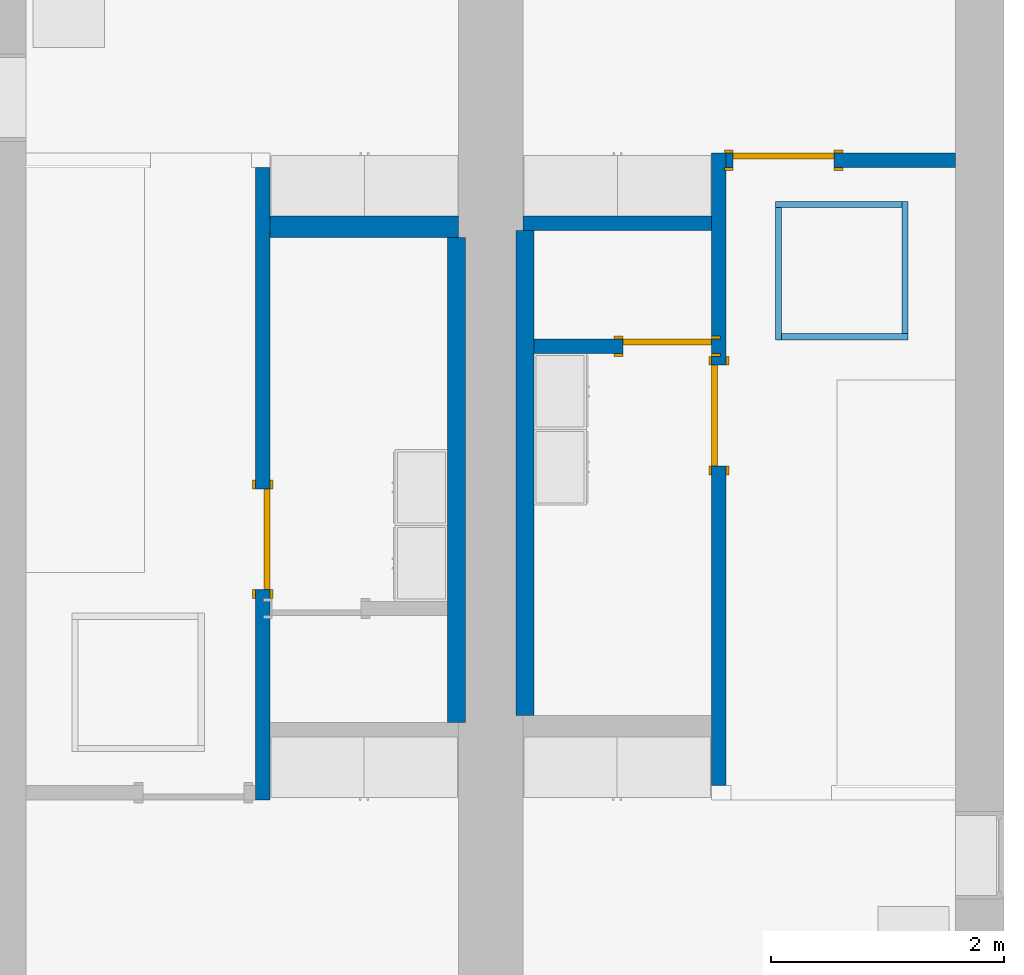
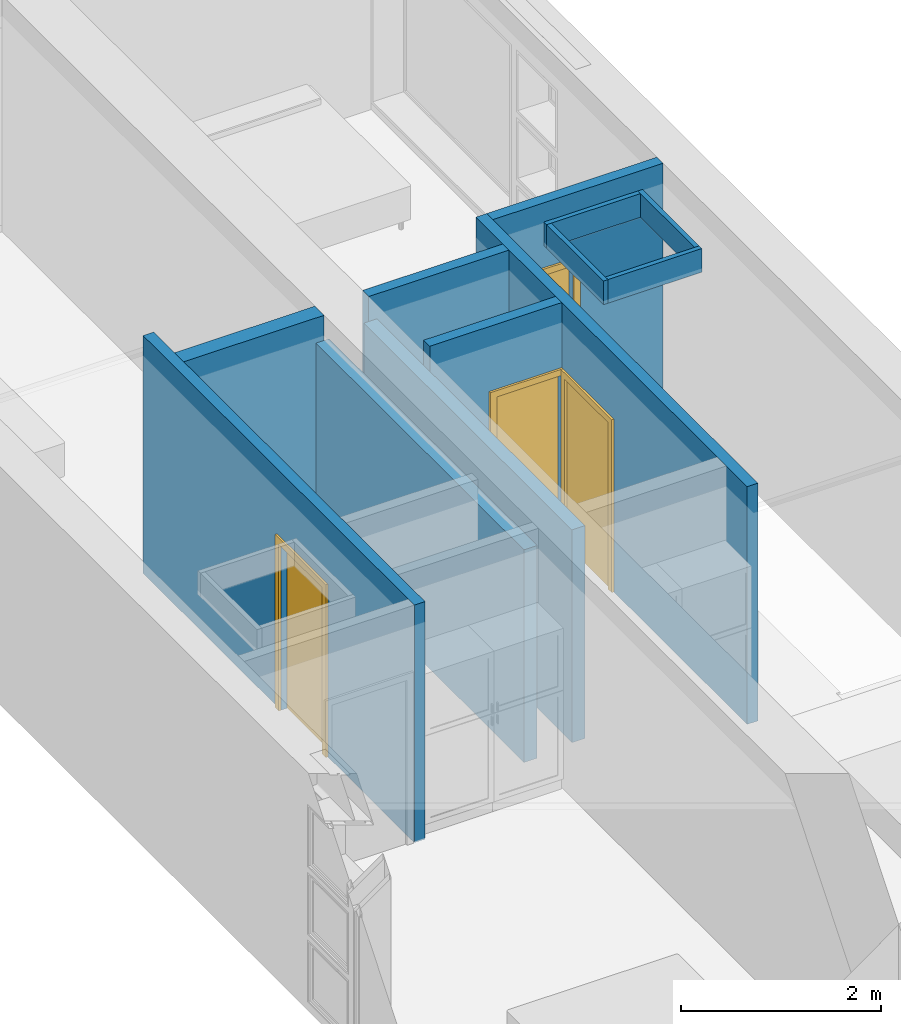
# One storey, part 3 of 16: 12 walls, 4 doors, 4 openings.
"""IFC2X3 building model written with IfcOpenShell, lengths in metres."""

from ifc_helpers import new_model, entity, si_unit, converted_unit, frame, frame_2d, origin, origin_2d_with_axis, place, context, project, spatial, polyline, rectangle, outline, extrude, source, transform, mapped, material, layer, layer_set, layer_usage, type_object, type_shapes, element, fill, save


model = new_model("IFC2X3")

# Units and contexts
model_context = context("Model", 3, precision=1e-09, world=origin())
plan_context = context("Plan", 3, precision=1e-09, world=origin())
ifc_project = project(units=[si_unit("LENGTHUNIT", "METRE"), si_unit("AREAUNIT", "SQUARE_METRE"), si_unit("VOLUMEUNIT", "CUBIC_METRE"), converted_unit("PLANEANGLEUNIT", "DEGREE", entity("IfcRatioMeasure", 0.01745329251994328), si_unit("PLANEANGLEUNIT", "RADIAN"), dimensions=[0, 0, 0, 0, 0, 0, 0]), si_unit("TIMEUNIT", "SECOND")], contexts=[model_context, plan_context])

# Site, building, storey
site_placement = place(None, origin())
site = spatial("IfcSite", under=ifc_project, at=site_placement, CompositionType="ELEMENT")
building_placement = place(site_placement, origin())
building = spatial("IfcBuilding", under=site, at=building_placement, CompositionType="ELEMENT")
storey_placement = place(building_placement, frame((0.0, 0.0, 3.100000000000378)))
storey = spatial("IfcBuildingStorey", under=building, at=storey_placement, Name="Level 2", CompositionType="ELEMENT", Elevation=3.100000000000378)

# Wall, opening, door
ifc_material_1 = material(Name="Plasterboard")
ifc_layer_1 = layer(ifc_material_1, 0.016)
ifc_material_2 = material(Name="Metal - Stud Layer")
ifc_layer_2 = layer(ifc_material_2, 0.092)
ifc_layer_3 = layer(ifc_material_1, 0.016)
ifc_layer_set_1 = layer_set([ifc_layer_1, ifc_layer_2, ifc_layer_3], Name="Basic Wall:Interior - Partition (92mm Stud)")
ifc_layer_usage_1 = layer_usage(ifc_layer_set_1, "AXIS2", "NEGATIVE", 0.062)
wall_1_placement = place(storey_placement, frame((2.444, -6.250000000000009, 0.0), z_axis=(0.0, 0.0, 1.0), x_axis=(0.0, -1.0, 0.0)))
wall_1 = element("IfcWallStandardCase", 1, at=wall_1_placement, inside=storey, material=ifc_layer_usage_1, Name="Basic Wall:Interior - Partition (92mm Stud)", ObjectType="Basic Wall:Interior - Partition (92mm Stud)", context=model_context, shape_type="SweptSolid", body=[
    extrude(rectangle(XDim=5.423999999999995, YDim=0.1240000000000002, at=frame_2d((2.711999999999998, 0.0), x_axis=(-1.0, 0.0))), origin(), (0.0, 0.0, 1.0), 2.900000000000012),
])
opening_1_placement = place(wall_1_placement, frame((2.75605117851058, -0.06200000000000567, 0.0)))
opening_1 = element("IfcOpeningElement", 2, at=opening_1_placement, cuts=wall_1, Name="M_Single-Flush:0864 x 2032mm:0864 x 2032mm:1", ObjectType="Opening", context=model_context, shape_type="SweptSolid", body=[
    extrude(rectangle(XDim=0.8639999999999994, YDim=2.032, at=frame_2d((1.016, 0.4319999999999993), x_axis=(0.0, 1.0))), frame((0.0, 0.0, 0.0), z_axis=(0.0, 1.0, 0.0), x_axis=(0.0, 0.0, 1.0)), (0.0, 0.0, 1.0), 0.124),
])
door_style_1 = type_object("IfcDoorStyle", Name="0864 x 2032mm", ConstructionType="NOTDEFINED", OperationType="SINGLE_SWING_RIGHT", ParameterTakesPrecedence=False, Sizeable=False)
shared_shape_1 = source(origin(), model_context, "Body", "SweptSolid", [
    extrude(outline(polyline([(-0.5079999999999999, -1.072999999999999), (0.5079999999999998, -1.072999999999999), (0.5079999999999998, 1.035000000000001), (0.4319999999999997, 1.035000000000001), (0.4319999999999997, -0.9970000000000019), (-0.4319999999999996, -0.9970000000000019), (-0.4319999999999996, 1.035000000000001), (-0.5079999999999999, 1.035000000000001), (-0.5079999999999999, -1.072999999999999)])), frame((0.4320000000000008, 0.1239999999999992, 1.035000000000001), z_axis=(0.0, 1.0, 0.0), x_axis=(1.0, 0.0, 0.0)), (0.0, 0.0, 1.0), 0.02499999999999444),
    extrude(outline(polyline([(-1.073, -0.5079999999999971), (1.035, -0.5079999999999971), (1.035, -0.4320000000000073), (-0.9969999999999997, -0.4320000000000073), (-0.9969999999999997, 0.4320000000000018), (1.035, 0.4320000000000018), (1.035, 0.5080000000000027), (-1.073, 0.5080000000000027), (-1.073, -0.5079999999999971)])), frame((0.4320000000000031, -0.02500000000000638, 1.035), z_axis=(0.0, 1.0, 0.0), x_axis=(0.0, 0.0, -1.0)), (0.0, 0.0, 1.0), 0.02500000000000558),
    extrude(rectangle(XDim=0.051, YDim=0.8639999999999998, at=origin_2d_with_axis()), frame((0.4320000000000005, 0.0984999999999992, 0.0), z_axis=(0.0, 0.0, 1.0), x_axis=(0.0, 1.0, 0.0)), (0.0, 0.0, 1.0), 2.032),
])
type_shapes(door_style_1, [shared_shape_1])
door_1_placement = place(opening_1_placement, origin())
door_1 = element("IfcDoor", 3, at=door_1_placement, inside=storey, type_object=door_style_1, Name="M_Single-Flush:0864 x 2032mm:0864 x 2032mm", ObjectType="0864 x 2032mm", OverallHeight=2.032, OverallWidth=0.8639999999999985, context=model_context, shape_type="MappedRepresentation", body=[
    mapped(shared_shape_1, transform((0.0, 0.0, 0.0), scale=1.0)),
])
fill(opening_1, door_1)

# Wall
ifc_layer_4 = layer(ifc_material_1, 0.016)
ifc_layer_5 = layer(ifc_material_2, 0.152)
ifc_layer_6 = layer(ifc_material_1, 0.016)
ifc_layer_set_2 = layer_set([ifc_layer_4, ifc_layer_5, ifc_layer_6], Name="Basic Wall:Interior - Plumbing (152mm Stud)")
ifc_layer_usage_2 = layer_usage(ifc_layer_set_2, "AXIS2", "NEGATIVE", 0.092)
wall_2_placement = place(storey_placement, frame((2.505999999999999, -6.758000000000003, 0.0)))
element("IfcWallStandardCase", 4, at=wall_2_placement, inside=storey, material=ifc_layer_usage_2, Name="Basic Wall:Interior - Plumbing (152mm Stud)", ObjectType="Basic Wall:Interior - Plumbing (152mm Stud)", context=model_context, shape_type="SweptSolid", body=[
    extrude(rectangle(XDim=1.618999999999992, YDim=0.1839999999999993, at=frame_2d((0.8094999999999958, 0.0), x_axis=(-1.0, 0.0))), origin(), (0.0, 0.0, 1.0), 2.900000000000012),
])

# Wall, opening, door
ifc_layer_usage_3 = layer_usage(ifc_layer_set_1, "AXIS2", "NEGATIVE", 0.062)
wall_3_placement = place(storey_placement, frame((6.356, -11.55, 0.0), z_axis=(0.0, 0.0, 1.0), x_axis=(0.0, 1.0, 0.0)))
wall_3 = element("IfcWallStandardCase", 5, at=wall_3_placement, inside=storey, material=ifc_layer_usage_3, Name="Basic Wall:Interior - Partition (92mm Stud)", ObjectType="Basic Wall:Interior - Partition (92mm Stud)", context=model_context, shape_type="SweptSolid", body=[
    extrude(rectangle(XDim=5.423999999999995, YDim=0.124, at=frame_2d((2.711999999999998, 0.0), x_axis=(-1.0, 0.0))), origin(), (0.0, 0.0, 1.0), 2.900000000000012),
])
opening_2_placement = place(wall_3_placement, frame((2.74061576492847, -0.0620000000000056, 0.0)))
opening_2 = element("IfcOpeningElement", 6, at=opening_2_placement, cuts=wall_3, Name="M_Single-Flush:0864 x 2032mm:0864 x 2032mm:1", ObjectType="Opening", context=model_context, shape_type="SweptSolid", body=[
    extrude(rectangle(XDim=0.8639999999999994, YDim=2.032, at=frame_2d((1.016, 0.4319999999999998), x_axis=(0.0, 1.0))), frame((0.0, 0.0, 0.0), z_axis=(0.0, 1.0, 0.0), x_axis=(0.0, 0.0, 1.0)), (0.0, 0.0, 1.0), 0.124),
])
door_2_placement = place(opening_2_placement, origin())
door_2 = element("IfcDoor", 7, at=door_2_placement, inside=storey, type_object=door_style_1, Name="M_Single-Flush:0864 x 2032mm:0864 x 2032mm", ObjectType="0864 x 2032mm", OverallHeight=2.032, OverallWidth=0.8639999999999995, context=model_context, shape_type="MappedRepresentation", body=[
    mapped(shared_shape_1, transform((0.0, 0.0, 0.0), scale=1.0)),
])
fill(opening_2, door_2)

ifc_layer_usage_4 = layer_usage(ifc_layer_set_1, "AXIS2", "NEGATIVE", 0.062)
wall_4_placement = place(storey_placement, frame((6.418000000000008, -6.188000000000002, 0.0)))
wall_4 = element("IfcWallStandardCase", 8, at=wall_4_placement, inside=storey, material=ifc_layer_usage_4, Name="Basic Wall:Interior - Partition (92mm Stud)", ObjectType="Basic Wall:Interior - Partition (92mm Stud)", context=model_context, shape_type="SweptSolid", body=[
    extrude(rectangle(XDim=1.964999999999982, YDim=0.124, at=frame_2d((0.982499999999991, 0.0), x_axis=(-1.0, 0.0))), origin(), (0.0, 0.0, 1.0), 2.900000000000012),
])
opening_3_placement = place(wall_4_placement, frame((0.06000000000000016, -0.0620000000000021, 0.0)))
opening_3 = element("IfcOpeningElement", 9, at=opening_3_placement, cuts=wall_4, Name="M_Single-Flush:0864 x 2032mm:0864 x 2032mm:1", ObjectType="Opening", context=model_context, shape_type="SweptSolid", body=[
    extrude(rectangle(XDim=0.8639999999999995, YDim=2.032, at=frame_2d((1.016, 0.432), x_axis=(0.0, -1.0))), frame((0.0, 0.0, 0.0), z_axis=(0.0, 1.0, 0.0), x_axis=(0.0, 0.0, 1.0)), (0.0, 0.0, 1.0), 0.124),
])
door_style_2 = type_object("IfcDoorStyle", Name="0864 x 2032mm", ConstructionType="NOTDEFINED", OperationType="SINGLE_SWING_LEFT", ParameterTakesPrecedence=False, Sizeable=False)
shared_shape_2 = source(origin(), model_context, "Body", "SweptSolid", [
    extrude(outline(polyline([(-0.5079999999999999, -1.072999999999999), (0.5079999999999998, -1.072999999999999), (0.5079999999999998, 1.035000000000001), (0.4319999999999997, 1.035000000000001), (0.4319999999999997, -0.9970000000000019), (-0.4319999999999996, -0.9970000000000019), (-0.4319999999999996, 1.035000000000001), (-0.5079999999999999, 1.035000000000001), (-0.5079999999999999, -1.072999999999999)])), frame((0.4320000000000002, 0.1489999999999882, 1.035000000000001), z_axis=(0.0, -1.0, 0.0), x_axis=(-1.0, 0.0, 0.0)), (0.0, 0.0, 1.0), 0.02499999999999444),
    extrude(outline(polyline([(-1.073, -0.5079999999999971), (1.035, -0.5079999999999971), (1.035, -0.4320000000000073), (-0.9969999999999997, -0.4320000000000073), (-0.9969999999999997, 0.4320000000000018), (1.035, 0.4320000000000018), (1.035, 0.5080000000000027), (-1.073, 0.5080000000000027), (-1.073, -0.5079999999999971)])), frame((0.4319999999999979, 0.0, 1.035), z_axis=(0.0, -1.0, 0.0), x_axis=(0.0, 0.0, -1.0)), (0.0, 0.0, 1.0), 0.02500000000000558),
    extrude(rectangle(XDim=0.8639999999999998, YDim=0.051, at=origin_2d_with_axis()), frame((0.4320000000000005, 0.09849999999999375, 0.0)), (0.0, 0.0, 1.0), 2.032),
])
type_shapes(door_style_2, [shared_shape_2])
door_3_placement = place(opening_3_placement, origin())
door_3 = element("IfcDoor", 10, at=door_3_placement, inside=storey, type_object=door_style_2, Name="M_Single-Flush:0864 x 2032mm:0864 x 2032mm", ObjectType="0864 x 2032mm", OverallHeight=2.032, OverallWidth=0.8639999999999995, context=model_context, shape_type="MappedRepresentation", body=[
    mapped(shared_shape_2, transform((0.0, 0.0, 0.0), scale=1.0)),
])
fill(opening_3, door_3)

# Walls
ifc_layer_usage_5 = layer_usage(ifc_layer_set_1, "AXIS2", "NEGATIVE", 0.062)
wall_5_placement = place(storey_placement, frame((4.674999999999989, -6.728000000000002, 0.0)))
element("IfcWallStandardCase", 11, at=wall_5_placement, inside=storey, material=ifc_layer_usage_5, Name="Basic Wall:Interior - Partition (92mm Stud)", ObjectType="Basic Wall:Interior - Partition (92mm Stud)", context=model_context, shape_type="SweptSolid", body=[
    extrude(rectangle(XDim=1.619000000000017, YDim=0.124, at=frame_2d((0.809500000000009, 0.0), x_axis=(-1.0, 0.0))), origin(), (0.0, 0.0, 1.0), 2.900000000000012),
])
ifc_layer_7 = layer(ifc_material_2, 0.136)
ifc_layer_8 = layer(ifc_material_1, 0.016)
ifc_layer_set_3 = layer_set([ifc_layer_7, ifc_layer_8], Name="Basic Wall:Interior - Furring (152 mm Stud)")
ifc_layer_usage_6 = layer_usage(ifc_layer_set_3, "AXIS2", "POSITIVE", -0.07600000000000001)
wall_6_placement = place(storey_placement, frame((4.693999999999989, -6.790000000000003, 0.0), z_axis=(0.0, 0.0, 1.0), x_axis=(0.0, -1.0, 0.0)))
element("IfcWallStandardCase", 12, at=wall_6_placement, inside=storey, material=ifc_layer_usage_6, Name="Basic Wall:Interior - Furring (152 mm Stud)", ObjectType="Basic Wall:Interior - Furring (152 mm Stud)", context=model_context, shape_type="SweptSolid", body=[
    extrude(rectangle(XDim=4.160000000000006, YDim=0.1520000000000001, at=frame_2d((2.080000000000003, 0.0), x_axis=(-1.0, 0.0))), origin(), (0.0, 0.0, 1.0), 2.595000000000012),
])
ifc_layer_usage_7 = layer_usage(ifc_layer_set_3, "AXIS2", "POSITIVE", -0.07600000000000001)
wall_7_placement = place(storey_placement, frame((4.105999999999982, -11.01, 0.0), z_axis=(0.0, 0.0, 1.0), x_axis=(0.0, 1.0, 0.0)))
element("IfcWallStandardCase", 13, at=wall_7_placement, inside=storey, material=ifc_layer_usage_7, Name="Basic Wall:Interior - Furring (152 mm Stud)", ObjectType="Basic Wall:Interior - Furring (152 mm Stud)", context=model_context, shape_type="SweptSolid", body=[
    extrude(rectangle(XDim=4.159999999999996, YDim=0.1520000000000001, at=frame_2d((2.079999999999998, 0.0), x_axis=(-1.0, 0.0))), origin(), (0.0, 0.0, 1.0), 2.595000000000012),
])

# Wall, opening, door
ifc_layer_usage_8 = layer_usage(ifc_layer_set_1, "AXIS2", "POSITIVE", -0.062)
wall_8_placement = place(storey_placement, frame((4.769999999999988, -7.783384235071523, 0.0)))
wall_8 = element("IfcWallStandardCase", 14, at=wall_8_placement, inside=storey, material=ifc_layer_usage_8, Name="Basic Wall:Interior - Partition (92mm Stud)", ObjectType="Basic Wall:Interior - Partition (92mm Stud)", context=model_context, shape_type="SweptSolid", body=[
    extrude(rectangle(XDim=1.524000000000019, YDim=0.124, at=frame_2d((0.7620000000000092, 0.0), x_axis=(-1.0, 0.0))), origin(), (0.0, 0.0, 1.0), 2.900000000000012),
])
opening_4_placement = place(wall_8_placement, frame((0.7613750000000165, -0.06200000000000323, 0.0)))
opening_4 = element("IfcOpeningElement", 15, at=opening_4_placement, cuts=wall_8, Name="M_Single-Flush:0762 x 2032mm:0762 x 2032mm:1", ObjectType="Opening", context=model_context, shape_type="SweptSolid", body=[
    extrude(rectangle(XDim=0.7619999999999997, YDim=2.032, at=frame_2d((1.016, 0.3809999999999995), x_axis=(0.0, 1.0))), frame((0.0, 0.0, 0.0), z_axis=(0.0, 1.0, 0.0), x_axis=(0.0, 0.0, 1.0)), (0.0, 0.0, 1.0), 0.124),
])
door_style_3 = type_object("IfcDoorStyle", Name="0762 x 2032mm", ConstructionType="NOTDEFINED", OperationType="SINGLE_SWING_RIGHT", ParameterTakesPrecedence=False, Sizeable=False)
shared_shape_3 = source(origin(), model_context, "Body", "SweptSolid", [
    extrude(outline(polyline([(-0.457, -1.072999999999999), (0.4569999999999999, -1.072999999999999), (0.4569999999999999, 1.035000000000001), (0.3809999999999998, 1.035000000000001), (0.3809999999999998, -0.9970000000000019), (-0.3809999999999997, -0.9970000000000019), (-0.3809999999999997, 1.035000000000001), (-0.457, 1.035000000000001), (-0.457, -1.072999999999999)])), frame((0.3810000000000009, 0.1239999999999993, 1.035000000000001), z_axis=(0.0, 1.0, 0.0), x_axis=(1.0, 0.0, 0.0)), (0.0, 0.0, 1.0), 0.02499999999999445),
    extrude(outline(polyline([(-1.073, -0.4569999999999971), (1.035, -0.4569999999999971), (1.035, -0.3810000000000074), (-0.9969999999999997, -0.3810000000000074), (-0.9969999999999997, 0.3810000000000018), (1.035, 0.3810000000000018), (1.035, 0.4570000000000027), (-1.073, 0.4570000000000027), (-1.073, -0.4569999999999971)])), frame((0.3810000000000031, -0.02500000000000627, 1.035), z_axis=(0.0, 1.0, 0.0), x_axis=(0.0, 0.0, -1.0)), (0.0, 0.0, 1.0), 0.02500000000000558),
    extrude(rectangle(XDim=0.051, YDim=0.7619999999999998, at=origin_2d_with_axis()), frame((0.3810000000000005, 0.09849999999999928, 0.0), z_axis=(0.0, 0.0, 1.0), x_axis=(0.0, 1.0, 0.0)), (0.0, 0.0, 1.0), 2.032),
])
type_shapes(door_style_3, [shared_shape_3])
door_4_placement = place(opening_4_placement, origin())
door_4 = element("IfcDoor", 16, at=door_4_placement, inside=storey, type_object=door_style_3, Name="M_Single-Flush:0762 x 2032mm:0762 x 2032mm", ObjectType="0762 x 2032mm", OverallHeight=2.032, OverallWidth=0.762, context=model_context, shape_type="MappedRepresentation", body=[
    mapped(shared_shape_3, transform((0.0, 0.0, 0.0), scale=1.0)),
])
fill(opening_4, door_4)

# Walls
ifc_layer_9 = layer(ifc_material_2, 0.038)
ifc_layer_10 = layer(ifc_material_1, 0.016)
ifc_layer_set_4 = layer_set([ifc_layer_9, ifc_layer_10], Name="Basic Wall:Interior - Furring (38 mm Stud)")
ifc_layer_usage_9 = layer_usage(ifc_layer_set_4, "AXIS2", "NEGATIVE", 0.027)
wall_9_placement = place(storey_placement, frame((6.84045000000003, -6.567450000000052, 2.612)))
element("IfcWallStandardCase", 17, at=wall_9_placement, inside=storey, material=ifc_layer_usage_9, Name="Basic Wall:Interior - Furring (38 mm Stud)", ObjectType="Basic Wall:Interior - Furring (38 mm Stud)", context=model_context, shape_type="SweptSolid", body=[
    extrude(rectangle(XDim=1.083100000000001, YDim=0.05400000000000072, at=frame_2d((0.5415500000000003, 0.0), x_axis=(-1.0, 0.0))), origin(), (0.0, 0.0, 1.0), 0.2880000000000125),
])
ifc_layer_usage_10 = layer_usage(ifc_layer_set_4, "AXIS2", "NEGATIVE", 0.027)
wall_10_placement = place(storey_placement, frame((6.867450000000031, -7.729550000000008, 2.612), z_axis=(0.0, 0.0, 1.0), x_axis=(0.0, 1.0, 0.0)))
element("IfcWallStandardCase", 18, at=wall_10_placement, inside=storey, material=ifc_layer_usage_10, Name="Basic Wall:Interior - Furring (38 mm Stud)", ObjectType="Basic Wall:Interior - Furring (38 mm Stud)", context=model_context, shape_type="SweptSolid", body=[
    extrude(rectangle(XDim=1.135099999999957, YDim=0.05400000000000072, at=frame_2d((0.5675499999999787, 0.0), x_axis=(-1.0, 0.0))), origin(), (0.0, 0.0, 1.0), 0.2880000000000125),
])
ifc_layer_usage_11 = layer_usage(ifc_layer_set_4, "AXIS2", "NEGATIVE", 0.027)
wall_11_placement = place(storey_placement, frame((7.977550000000031, -7.702550000000009, 2.612), z_axis=(0.0, 0.0, 1.0), x_axis=(-1.0, 0.0, 0.0)))
element("IfcWallStandardCase", 19, at=wall_11_placement, inside=storey, material=ifc_layer_usage_11, Name="Basic Wall:Interior - Furring (38 mm Stud)", ObjectType="Basic Wall:Interior - Furring (38 mm Stud)", context=model_context, shape_type="SweptSolid", body=[
    extrude(rectangle(XDim=1.083100000000001, YDim=0.05400000000000071, at=frame_2d((0.5415500000000003, 0.0), x_axis=(-1.0, 0.0))), origin(), (0.0, 0.0, 1.0), 0.2880000000000125),
])
ifc_layer_usage_12 = layer_usage(ifc_layer_set_4, "AXIS2", "NEGATIVE", 0.027)
wall_12_placement = place(storey_placement, frame((7.95055000000003, -6.540450000000051, 2.612), z_axis=(0.0, 0.0, 1.0), x_axis=(0.0, -1.0, 0.0)))
element("IfcWallStandardCase", 20, at=wall_12_placement, inside=storey, material=ifc_layer_usage_12, Name="Basic Wall:Interior - Furring (38 mm Stud)", ObjectType="Basic Wall:Interior - Furring (38 mm Stud)", context=model_context, shape_type="SweptSolid", body=[
    extrude(rectangle(XDim=1.13509999999996, YDim=0.05400000000000072, at=frame_2d((0.5675499999999798, 0.0), x_axis=(-1.0, 0.0))), origin(), (0.0, 0.0, 1.0), 0.2880000000000125),
])

save(model, "model.ifc")
